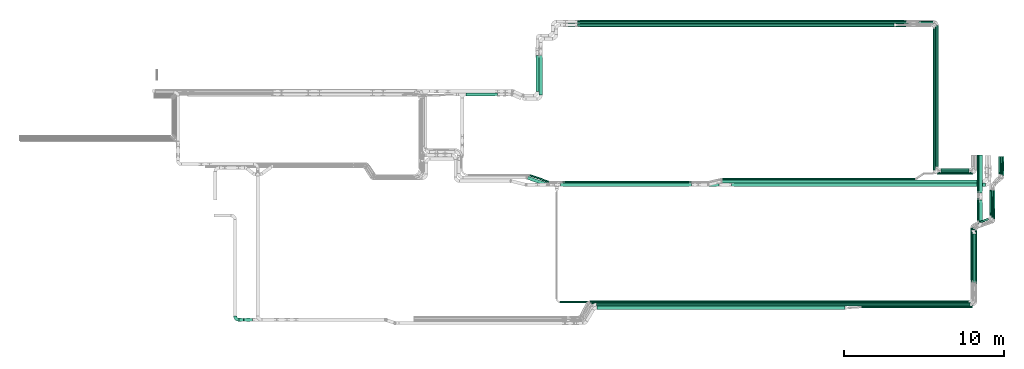
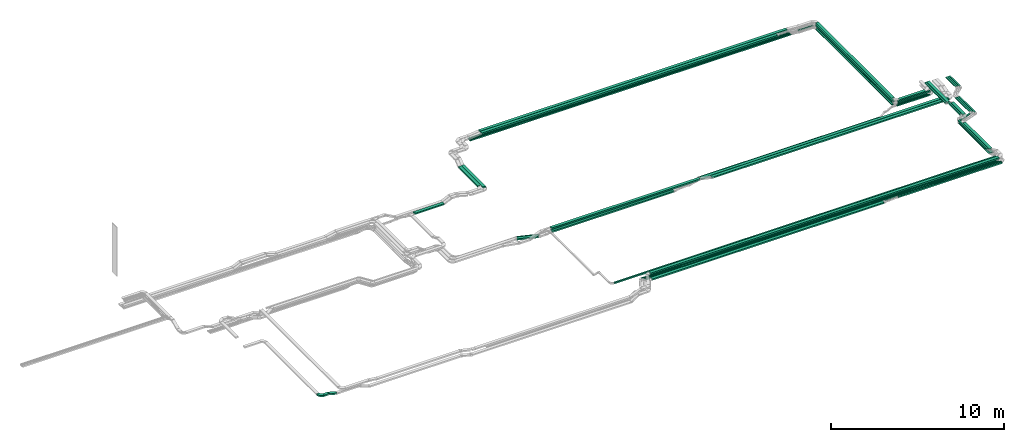
# One storey, part 2 of 23: 52 flow segments, 1 flow fitting.
"""IFC2X3 building model written with IfcOpenShell, lengths in millimetres."""

from ifc_helpers import new_model, entity, si_unit, converted_unit, derived_unit, direction, frame, frame_2d, origin, origin_2d_with_axis, place, context, subcontext, project, spatial, polyline, circle_curve, parameter, trimmed, segment, composite_curve, rectangle, outline, extrude, source, transform, mapped, material, type_object, type_shapes, element, save


model = new_model("IFC2X3")

# Units and contexts
model_context = context("Model", 3, precision=0.01, world=origin(), true_north=direction((6.12303176911189e-17, 1.0)))
body_context = subcontext(model_context, "Body", "Model", "MODEL_VIEW")
ifc_project = project(units=[si_unit("LENGTHUNIT", "METRE", prefix="MILLI"), si_unit("AREAUNIT", "SQUARE_METRE"), si_unit("VOLUMEUNIT", "CUBIC_METRE"), converted_unit("PLANEANGLEUNIT", "DEGREE", entity("IfcRatioMeasure", 0.0174532925199433), si_unit("PLANEANGLEUNIT", "RADIAN"), dimensions=[0, 0, 0, 0, 0, 0, 0]), si_unit("MASSUNIT", "GRAM", prefix="KILO"), derived_unit("MASSDENSITYUNIT", [(si_unit("MASSUNIT", "GRAM", prefix="KILO"), 1), (si_unit("LENGTHUNIT", "METRE"), -3)]), derived_unit("MOMENTOFINERTIAUNIT", [(si_unit("LENGTHUNIT", "METRE"), 4)]), si_unit("TIMEUNIT", "SECOND"), si_unit("FREQUENCYUNIT", "HERTZ"), si_unit("THERMODYNAMICTEMPERATUREUNIT", "DEGREE_CELSIUS"), derived_unit("THERMALTRANSMITTANCEUNIT", [(si_unit("MASSUNIT", "GRAM", prefix="KILO"), 1), (si_unit("THERMODYNAMICTEMPERATUREUNIT", "KELVIN"), -1), (si_unit("TIMEUNIT", "SECOND"), -3)]), derived_unit("VOLUMETRICFLOWRATEUNIT", [(si_unit("LENGTHUNIT", "METRE"), 3), (si_unit("TIMEUNIT", "SECOND"), -1)]), derived_unit("MASSFLOWRATEUNIT", [(si_unit("MASSUNIT", "GRAM", prefix="KILO"), 1), (si_unit("TIMEUNIT", "SECOND"), -1)]), derived_unit("ROTATIONALFREQUENCYUNIT", [(si_unit("TIMEUNIT", "SECOND"), -1)]), si_unit("ELECTRICCURRENTUNIT", "AMPERE"), si_unit("ELECTRICVOLTAGEUNIT", "VOLT"), si_unit("POWERUNIT", "WATT"), si_unit("FORCEUNIT", "NEWTON", prefix="KILO"), si_unit("ILLUMINANCEUNIT", "LUX"), si_unit("LUMINOUSFLUXUNIT", "LUMEN"), si_unit("LUMINOUSINTENSITYUNIT", "CANDELA"), derived_unit("USERDEFINED", [(si_unit("MASSUNIT", "GRAM", prefix="KILO"), -1), (si_unit("LENGTHUNIT", "METRE"), -2), (si_unit("TIMEUNIT", "SECOND"), 3), (si_unit("LUMINOUSFLUXUNIT", "LUMEN"), 1)]), derived_unit("LINEARVELOCITYUNIT", [(si_unit("LENGTHUNIT", "METRE"), 1), (si_unit("TIMEUNIT", "SECOND"), -1)]), si_unit("PRESSUREUNIT", "PASCAL"), derived_unit("USERDEFINED", [(si_unit("LENGTHUNIT", "METRE"), -2), (si_unit("MASSUNIT", "GRAM", prefix="KILO"), 1), (si_unit("TIMEUNIT", "SECOND"), -2)]), derived_unit("LINEARFORCEUNIT", [(si_unit("MASSUNIT", "GRAM", prefix="KILO"), 1), (si_unit("LENGTHUNIT", "METRE"), 1), (si_unit("TIMEUNIT", "SECOND"), -2), (si_unit("LENGTHUNIT", "METRE"), -1)]), derived_unit("PLANARFORCEUNIT", [(si_unit("MASSUNIT", "GRAM", prefix="KILO"), 1), (si_unit("LENGTHUNIT", "METRE"), 1), (si_unit("TIMEUNIT", "SECOND"), -2), (si_unit("LENGTHUNIT", "METRE"), -2)])], contexts=[model_context])

# Site, building, storey
site_placement = place(None, origin())
site = spatial("IfcSite", under=ifc_project, at=site_placement, CompositionType="ELEMENT")
building_placement = place(site_placement, origin())
building = spatial("IfcBuilding", under=site, at=building_placement, CompositionType="ELEMENT")
storey_placement = place(building_placement, frame((0.0, 0.0, 24000.0)))
storey = spatial("IfcBuildingStorey", under=building, at=storey_placement, CompositionType="ELEMENT", Elevation=24000.0)

# Flow segments
cable_carrier_segment_type = type_object("IfcCableCarrierSegmentType", PredefinedType="CABLETRAYSEGMENT")
flow_segment_1_placement = place(storey_placement, frame((35765.62, 14367.82, 2650.0)))
element("IfcFlowSegment", 1, at=flow_segment_1_placement, inside=storey, type_object=cable_carrier_segment_type, context=body_context, shape_type="SweptSolid", body=[
    extrude(rectangle(XDim=1961.74448976482, YDim=199.999999999998, at=origin_2d_with_axis()), frame((980.87, 100.0, 0.0)), (0.0, 0.0, 1.0), 100.000000000003),
])
for number, where in (
    (2, (65130.08, 9971.0, 2972.83)),
    (3, (65020.08, 9861.0, 2972.83)),
):
    element("IfcFlowSegment", number, at=place(storey_placement, frame(where)), inside=storey, type_object=cable_carrier_segment_type, context=body_context, shape_type="SweptSolid", body=[
        extrude(rectangle(XDim=8798.00000000002, YDim=99.9999999999946, at=origin_2d_with_axis()), frame((50.0, 4399.0, 0.0), z_axis=(0.0, 0.0, 1.0), x_axis=(0.0, -1.0, 0.0)), (0.0, 0.0, 1.0), 49.9999999999973),
    ])
flow_segment_2_placement = place(storey_placement, frame((21625.98, 315.0, 3300.0)))
element("IfcFlowSegment", 4, at=flow_segment_2_placement, inside=storey, type_object=cable_carrier_segment_type, context=body_context, shape_type="SweptSolid", body=[
    extrude(rectangle(XDim=280.71716103048, YDim=200.0, at=origin_2d_with_axis()), frame((140.36, 100.0, 0.0)), (0.0, 0.0, 1.0), 100.000000000003),
])
flow_segment_3_placement = place(storey_placement, frame((21909.72, 315.0, 3153.98)))
element("IfcFlowSegment", 5, at=flow_segment_3_placement, inside=storey, type_object=cable_carrier_segment_type, context=body_context, shape_type="SweptSolid", body=[
    extrude(rectangle(XDim=99.9999999999958, YDim=200.0, at=origin_2d_with_axis()), frame((13.25, 100.0, 193.83), z_axis=(0.964271449330498, 0.0, -0.26491616033391), x_axis=(0.26491616033391, 0.0, 0.964271449330498)), (0.0, 0.0, 1.0), 549.651195395299),
])
flow_segment_4_placement = place(storey_placement, frame((43924.88, 1069.69, 3217.23)))
element("IfcFlowSegment", 6, at=flow_segment_4_placement, inside=storey, type_object=cable_carrier_segment_type, context=body_context, shape_type="SweptSolid", body=[
    extrude(rectangle(XDim=15479.0908343116, YDim=200.0, at=origin_2d_with_axis()), frame((7739.55, 100.0, 0.0), z_axis=(0.0, 0.0, 1.0), x_axis=(-1.0, 0.0, 0.0)), (0.0, 0.0, 1.0), 100.000000000003),
])
flow_segment_5_placement = place(storey_placement, frame((51733.9, 9154.99, 2805.0)))
element("IfcFlowSegment", 7, at=flow_segment_5_placement, inside=storey, type_object=cable_carrier_segment_type, context=body_context, shape_type="SweptSolid", body=[
    extrude(rectangle(XDim=12038.4671980296, YDim=99.9999999999989, at=origin_2d_with_axis()), frame((6019.23, 50.0, 0.0)), (0.0, 0.0, 1.0), 49.9999999999973),
])
flow_segment_6_placement = place(storey_placement, frame((52335.62, 8734.99, 2805.0)))
element("IfcFlowSegment", 8, at=flow_segment_6_placement, inside=storey, type_object=cable_carrier_segment_type, context=body_context, shape_type="SweptSolid", body=[
    extrude(rectangle(XDim=15832.6193035877, YDim=200.0, at=origin_2d_with_axis()), frame((7916.31, 100.0, 0.0)), (0.0, 0.0, 1.0), 100.000000000003),
])
flow_segment_7_placement = place(storey_placement, frame((42732.4, 18910.0, 3245.4)))
element("IfcFlowSegment", 9, at=flow_segment_7_placement, inside=storey, type_object=cable_carrier_segment_type, context=body_context, shape_type="SweptSolid", body=[
    extrude(rectangle(XDim=20513.0370032506, YDim=200.000000000002, at=origin_2d_with_axis()), frame((10256.52, 100.0, 0.0)), (0.0, 0.0, 1.0), 100.000000000003),
])
flow_segment_8_placement = place(storey_placement, frame((42732.38, 18700.0, 3245.4)))
element("IfcFlowSegment", 10, at=flow_segment_8_placement, inside=storey, type_object=cable_carrier_segment_type, context=body_context, shape_type="SweptSolid", body=[
    extrude(rectangle(XDim=19736.1029536707, YDim=199.999999999998, at=origin_2d_with_axis()), frame((9868.05, 100.0, 0.0)), (0.0, 0.0, 1.0), 100.000000000003),
])
flow_segment_9_placement = place(storey_placement, frame((41967.53, 18700.0, 3045.4)))
element("IfcFlowSegment", 11, at=flow_segment_9_placement, inside=storey, type_object=cable_carrier_segment_type, context=body_context, shape_type="SweptSolid", body=[
    extrude(rectangle(XDim=21395.2924590022, YDim=99.9999999999989, at=origin_2d_with_axis()), frame((10697.65, 50.0, 0.0)), (0.0, 0.0, 1.0), 49.9999999999973),
])
flow_segment_10_placement = place(storey_placement, frame((41968.48, 18810.0, 3045.4)))
element("IfcFlowSegment", 12, at=flow_segment_10_placement, inside=storey, type_object=cable_carrier_segment_type, context=body_context, shape_type="SweptSolid", body=[
    extrude(rectangle(XDim=21395.2882878374, YDim=99.9999999999989, at=origin_2d_with_axis()), frame((10697.64, 50.0, 0.0)), (0.0, 0.0, 1.0), 49.9999999999973),
])
flow_segment_11_placement = place(storey_placement, frame((41967.53, 18920.0, 3045.4)))
element("IfcFlowSegment", 13, at=flow_segment_11_placement, inside=storey, type_object=cable_carrier_segment_type, context=body_context, shape_type="SweptSolid", body=[
    extrude(rectangle(XDim=21395.2924590022, YDim=99.9999999999989, at=origin_2d_with_axis()), frame((10697.65, 50.0, 0.0)), (0.0, 0.0, 1.0), 49.9999999999973),
])
flow_segment_12_placement = place(storey_placement, frame((41771.84, 8949.99, 2720.0)))
element("IfcFlowSegment", 14, at=flow_segment_12_placement, inside=storey, type_object=cable_carrier_segment_type, context=body_context, shape_type="SweptSolid", body=[
    extrude(rectangle(XDim=8053.84090120549, YDim=99.9999999999989, at=origin_2d_with_axis()), frame((4026.92, 50.0, 0.0), z_axis=(0.0, 0.0, 1.0), x_axis=(-1.0, 0.0, 0.0)), (0.0, 0.0, 1.0), 49.9999999999973),
])
flow_segment_13_placement = place(storey_placement, frame((41674.25, 8739.99, 2720.0)))
element("IfcFlowSegment", 15, at=flow_segment_13_placement, inside=storey, type_object=cable_carrier_segment_type, context=body_context, shape_type="SweptSolid", body=[
    extrude(rectangle(XDim=8148.49829971334, YDim=200.0, at=origin_2d_with_axis()), frame((4074.25, 100.0, 0.0), z_axis=(0.0, 0.0, 1.0), x_axis=(-1.0, 0.0, 0.0)), (0.0, 0.0, 1.0), 100.000000000003),
])
flow_segment_14_placement = place(storey_placement, frame((51739.88, 8944.99, 2805.0)))
element("IfcFlowSegment", 16, at=flow_segment_14_placement, inside=storey, type_object=cable_carrier_segment_type, context=body_context, shape_type="SweptSolid", body=[
    extrude(rectangle(XDim=16237.8207927538, YDim=200.0, at=origin_2d_with_axis()), frame((8118.91, 100.0, 0.0)), (0.0, 0.0, 1.0), 100.000000000003),
])
flow_segment_15_placement = place(storey_placement, frame((40330.6, 14420.31, 2883.62)))
element("IfcFlowSegment", 17, at=flow_segment_15_placement, inside=storey, type_object=cable_carrier_segment_type, context=body_context, shape_type="SweptSolid", body=[
    extrude(rectangle(XDim=2490.37832088763, YDim=200.000000000007, at=origin_2d_with_axis()), frame((100.0, 1245.19, 0.0), z_axis=(0.0, 0.0, 1.0), x_axis=(0.0, -1.0, 0.0)), (0.0, 0.0, 1.0), 100.000000000008),
])
flow_segment_16_placement = place(storey_placement, frame((40120.6, 14651.31, 2883.62)))
element("IfcFlowSegment", 18, at=flow_segment_16_placement, inside=storey, type_object=cable_carrier_segment_type, context=body_context, shape_type="SweptSolid", body=[
    extrude(rectangle(XDim=2256.12450469831, YDim=200.000000000007, at=origin_2d_with_axis()), frame((100.0, 1128.06, 0.0), z_axis=(0.0, 0.0, 1.0), x_axis=(0.0, -1.0, 0.0)), (0.0, 0.0, 1.0), 100.000000000003),
])
flow_segment_17_placement = place(storey_placement, frame((39578.79, 8759.66, 2660.0)))
element("IfcFlowSegment", 19, at=flow_segment_17_placement, inside=storey, type_object=cable_carrier_segment_type, context=body_context, shape_type="SweptSolid", body=[
    extrude(rectangle(XDim=1270.99252740195, YDim=200.000000000001, at=origin_2d_with_axis()), frame((633.16, 302.81, 0.0), z_axis=(0.0, 0.0, 1.0), x_axis=(-0.944737568154261, 0.327827587792688, 0.0)), (0.0, 0.0, 1.0), 100.000000000003),
])
flow_segment_18_placement = place(storey_placement, frame((39717.22, 8964.13, 2660.0)))
element("IfcFlowSegment", 20, at=flow_segment_18_placement, inside=storey, type_object=cable_carrier_segment_type, context=body_context, shape_type="SweptSolid", body=[
    extrude(rectangle(XDim=1287.8496907078, YDim=100.000000000007, at=origin_2d_with_axis()), frame((624.73, 258.33, 0.0), z_axis=(0.0, 0.0, 1.0), x_axis=(-0.944737568154257, 0.327827587792702, 0.0)), (0.0, 0.0, 1.0), 49.9999999999929),
])
flow_segment_19_placement = place(storey_placement, frame((41655.11, 8734.99, 2970.0)))
element("IfcFlowSegment", 21, at=flow_segment_19_placement, inside=storey, type_object=cable_carrier_segment_type, context=body_context, shape_type="SweptSolid", body=[
    extrude(rectangle(XDim=9887.21265595425, YDim=200.0, at=origin_2d_with_axis()), frame((4943.61, 100.0, 0.0), z_axis=(0.0, 0.0, 1.0), x_axis=(-1.0, 0.0, 0.0)), (0.0, 0.0, 1.0), 100.000000000003),
])
flow_segment_20_placement = place(storey_placement, frame((63984.79, 18920.0, 2972.83)))
element("IfcFlowSegment", 22, at=flow_segment_20_placement, inside=storey, type_object=cable_carrier_segment_type, context=body_context, shape_type="SweptSolid", body=[
    extrude(rectangle(XDim=994.292459002089, YDim=99.9999999999989, at=origin_2d_with_axis()), frame((497.15, 50.0, 0.0), z_axis=(0.0, 0.0, 1.0), x_axis=(-1.0, 0.0, 0.0)), (0.0, 0.0, 1.0), 49.9999999999973),
])
flow_segment_21_placement = place(storey_placement, frame((65381.08, 9720.0, 2972.83)))
element("IfcFlowSegment", 23, at=flow_segment_21_placement, inside=storey, type_object=cable_carrier_segment_type, context=body_context, shape_type="SweptSolid", body=[
    extrude(rectangle(XDim=1753.44655483797, YDim=99.9999999999989, at=origin_2d_with_axis()), frame((876.72, 50.0, 0.0)), (0.0, 0.0, 1.0), 49.9999999999973),
])
flow_segment_22_placement = place(storey_placement, frame((65271.08, 9610.0, 2972.83)))
element("IfcFlowSegment", 24, at=flow_segment_22_placement, inside=storey, type_object=cable_carrier_segment_type, context=body_context, shape_type="SweptSolid", body=[
    extrude(rectangle(XDim=1973.44655483796, YDim=99.9999999999989, at=origin_2d_with_axis()), frame((986.72, 50.0, 0.0)), (0.0, 0.0, 1.0), 49.9999999999973),
])
flow_segment_23_placement = place(storey_placement, frame((64910.08, 9730.0, 2972.83)))
element("IfcFlowSegment", 25, at=flow_segment_23_placement, inside=storey, type_object=cable_carrier_segment_type, context=body_context, shape_type="SweptSolid", body=[
    extrude(rectangle(XDim=8819.00000000003, YDim=99.9999999999946, at=origin_2d_with_axis()), frame((50.0, 4409.5, 0.0), z_axis=(0.0, 0.0, 1.0), x_axis=(0.0, -1.0, 0.0)), (0.0, 0.0, 1.0), 49.9999999999973),
])
flow_segment_24_placement = place(storey_placement, frame((65030.08, 9961.0, 3187.83)))
element("IfcFlowSegment", 26, at=flow_segment_24_placement, inside=storey, type_object=cable_carrier_segment_type, context=body_context, shape_type="SweptSolid", body=[
    extrude(rectangle(XDim=8798.00000000003, YDim=200.000000000007, at=origin_2d_with_axis()), frame((100.0, 4399.0, 0.0), z_axis=(0.0, 0.0, 1.0), x_axis=(0.0, -1.0, 0.0)), (0.0, 0.0, 1.0), 100.000000000003),
])
flow_segment_25_placement = place(storey_placement, frame((65381.08, 9610.0, 3187.83)))
element("IfcFlowSegment", 27, at=flow_segment_25_placement, inside=storey, type_object=cable_carrier_segment_type, context=body_context, shape_type="SweptSolid", body=[
    extrude(rectangle(XDim=1738.00000000001, YDim=200.0, at=origin_2d_with_axis()), frame((869.0, 100.0, 0.0), z_axis=(0.0, 0.0, 1.0), x_axis=(-1.0, 0.0, 0.0)), (0.0, 0.0, 1.0), 100.000000000003),
])
flow_segment_26_placement = place(storey_placement, frame((65140.08, 9500.0, 2972.83)))
element("IfcFlowSegment", 28, at=flow_segment_26_placement, inside=storey, type_object=cable_carrier_segment_type, context=body_context, shape_type="SweptSolid", body=[
    extrude(rectangle(XDim=2214.44655483797, YDim=99.9999999999989, at=origin_2d_with_axis()), frame((1107.22, 50.0, 0.0), z_axis=(0.0, 0.0, 1.0), x_axis=(-1.0, 0.0, 0.0)), (0.0, 0.0, 1.0), 49.9999999999973),
])
flow_segment_27_placement = place(storey_placement, frame((64920.08, 9751.0, 3187.83)))
element("IfcFlowSegment", 29, at=flow_segment_27_placement, inside=storey, type_object=cable_carrier_segment_type, context=body_context, shape_type="SweptSolid", body=[
    extrude(rectangle(XDim=8848.00000000016, YDim=99.9999999999946, at=origin_2d_with_axis()), frame((50.0, 4424.0, 0.0), z_axis=(0.0, 0.0, 1.0), x_axis=(0.0, -1.0, 0.0)), (0.0, 0.0, 1.0), 100.000000000003),
])
flow_segment_28_placement = place(storey_placement, frame((65171.08, 9500.0, 3187.83)))
element("IfcFlowSegment", 30, at=flow_segment_28_placement, inside=storey, type_object=cable_carrier_segment_type, context=body_context, shape_type="SweptSolid", body=[
    extrude(rectangle(XDim=2183.44655483798, YDim=99.9999999999989, at=origin_2d_with_axis()), frame((1091.72, 50.0, 0.0)), (0.0, 0.0, 1.0), 100.000000000003),
])
flow_segment_29_placement = place(storey_placement, frame((67766.35, 8313.75, 2955.27)))
element("IfcFlowSegment", 31, at=flow_segment_29_placement, inside=storey, type_object=cable_carrier_segment_type, context=body_context, shape_type="SweptSolid", body=[
    extrude(rectangle(XDim=2386.77265957814, YDim=200.000000000007, at=origin_2d_with_axis()), frame((100.0, 1193.39, 0.0), z_axis=(0.0, 0.0, 1.0), x_axis=(0.0, 1.0, 0.0)), (0.0, 0.0, 1.0), 100.000000000003),
])
flow_segment_30_placement = place(storey_placement, frame((68996.32, 9477.22, 2970.08)))
element("IfcFlowSegment", 32, at=flow_segment_30_placement, inside=storey, type_object=cable_carrier_segment_type, context=body_context, shape_type="SweptSolid", body=[
    extrude(rectangle(XDim=49.9999999999984, YDim=1113.08678124436, at=frame_2d((0.0, 0.0), x_axis=(0.0, 1.0))), frame((0.0, 556.66, 27.83), z_axis=(1.0, -1.28642484897292e-06, 6.54438427708494e-09), x_axis=(1.28644149537419e-06, 0.999987060117084, -0.00508719930179811)), (0.0, 0.0, 1.0), 100.000000000017),
])
flow_segment_31_placement = place(storey_placement, frame((69106.32, 9459.66, 2970.08)))
element("IfcFlowSegment", 33, at=flow_segment_31_placement, inside=storey, type_object=cable_carrier_segment_type, context=body_context, shape_type="SweptSolid", body=[
    extrude(rectangle(XDim=50.0000000000039, YDim=1130.64982762595, at=frame_2d((0.0, 0.0), x_axis=(0.0, 1.0))), frame((0.0, 565.44, 27.8), z_axis=(1.0, -1.19737642217187e-06, 5.92293818108424e-09), x_axis=(1.1973910712753e-06, 0.999987765814664, -0.00494653611768659)), (0.0, 0.0, 1.0), 99.9999999999969),
])
flow_segment_32_placement = place(storey_placement, frame((69216.32, 9406.28, 2970.08)))
element("IfcFlowSegment", 34, at=flow_segment_32_placement, inside=storey, type_object=cable_carrier_segment_type, context=body_context, shape_type="SweptSolid", body=[
    extrude(rectangle(XDim=50.0000000000024, YDim=1184.03397215071, at=frame_2d((0.0, 0.0), x_axis=(0.0, 1.0))), frame((0.0, 592.13, 27.86), z_axis=(1.0, 0.0, 0.0), x_axis=(0.0, 0.999988349268031, -0.00482714493236797)), (0.0, 0.0, 1.0), 100.000000000003),
])
flow_segment_33_placement = place(storey_placement, frame((67460.79, 6325.18, 2990.05)))
element("IfcFlowSegment", 35, at=flow_segment_33_placement, inside=storey, type_object=cable_carrier_segment_type, context=body_context, shape_type="SweptSolid", body=[
    extrude(rectangle(XDim=936.699448046719, YDim=99.999999950971, at=origin_2d_with_axis()), frame((455.13, 214.62, 0.01), z_axis=(2.92307110406685e-05, 1.12284692556801e-05, 1.0), x_axis=(-0.933496521062262, -0.358586452873139, 3.13131440415812e-05)), (0.0, 0.0, 1.0), 49.9999999754865),
])
flow_segment_34_placement = place(storey_placement, frame((67656.35, 8312.3, 2955.27)))
element("IfcFlowSegment", 36, at=flow_segment_34_placement, inside=storey, type_object=cable_carrier_segment_type, context=body_context, shape_type="SweptSolid", body=[
    extrude(rectangle(XDim=2376.94076012938, YDim=99.9999999999946, at=origin_2d_with_axis()), frame((50.0, 1188.47, 0.0), z_axis=(0.0, 0.0, 1.0), x_axis=(0.0, 1.0, 0.0)), (0.0, 0.0, 1.0), 100.000000000008),
])
flow_segment_35_placement = place(storey_placement, frame((67766.35, 6490.72, 3190.89)))
element("IfcFlowSegment", 37, at=flow_segment_35_placement, inside=storey, type_object=cable_carrier_segment_type, context=body_context, shape_type="SweptSolid", body=[
    extrude(rectangle(XDim=1383.98185180537, YDim=200.000000000007, at=origin_2d_with_axis()), frame((100.0, 691.99, 0.0), z_axis=(0.0, 0.0, 1.0), x_axis=(0.0, -1.0, 0.0)), (0.0, 0.0, 1.0), 100.000000000003),
])
flow_segment_36_placement = place(storey_placement, frame((67656.35, 6589.61, 3190.89)))
element("IfcFlowSegment", 38, at=flow_segment_36_placement, inside=storey, type_object=cable_carrier_segment_type, context=body_context, shape_type="SweptSolid", body=[
    extrude(rectangle(XDim=1440.33081274158, YDim=99.9999999999946, at=origin_2d_with_axis()), frame((50.0, 720.17, 0.0), z_axis=(0.0, 0.0, 1.0), x_axis=(0.0, -1.0, 0.0)), (0.0, 0.0, 1.0), 99.9999999999989),
])
flow_segment_37_placement = place(storey_placement, frame((67299.5, 2648.59, 2990.08)))
element("IfcFlowSegment", 39, at=flow_segment_37_placement, inside=storey, type_object=cable_carrier_segment_type, context=body_context, shape_type="SweptSolid", body=[
    extrude(rectangle(XDim=3535.21004703669, YDim=99.9999999999946, at=origin_2d_with_axis()), frame((50.0, 1767.61, 0.0), z_axis=(0.0, 0.0, 1.0), x_axis=(0.0, -1.0, 0.0)), (0.0, 0.0, 1.0), 49.9999999999973),
])
flow_segment_38_placement = place(storey_placement, frame((67409.5, 2647.82, 2990.08)))
element("IfcFlowSegment", 40, at=flow_segment_38_placement, inside=storey, type_object=cable_carrier_segment_type, context=body_context, shape_type="SweptSolid", body=[
    extrude(rectangle(XDim=3441.21407318068, YDim=99.9999999999946, at=origin_2d_with_axis()), frame((50.0, 1720.61, 0.0), z_axis=(0.0, 0.0, 1.0), x_axis=(0.0, -1.0, 0.0)), (0.0, 0.0, 1.0), 49.9999999999973),
])
flow_segment_39_placement = place(storey_placement, frame((67519.5, 2648.59, 2990.08)))
element("IfcFlowSegment", 41, at=flow_segment_39_placement, inside=storey, type_object=cable_carrier_segment_type, context=body_context, shape_type="SweptSolid", body=[
    extrude(rectangle(XDim=3340.44295348635, YDim=99.9999999999946, at=origin_2d_with_axis()), frame((50.0, 1670.22, 0.0), z_axis=(0.0, 0.0, 1.0), x_axis=(0.0, -1.0, 0.0)), (0.0, 0.0, 1.0), 49.9999999999973),
])
flow_segment_40_placement = place(storey_placement, frame((67245.11, 2757.32, 3190.89)))
element("IfcFlowSegment", 42, at=flow_segment_40_placement, inside=storey, type_object=cable_carrier_segment_type, context=body_context, shape_type="SweptSolid", body=[
    extrude(rectangle(XDim=3397.478378517, YDim=99.9999999999946, at=origin_2d_with_axis()), frame((50.0, 1698.74, 0.0), z_axis=(0.0, 0.0, 1.0), x_axis=(0.0, -1.0, 0.0)), (0.0, 0.0, 1.0), 100.000000000003),
])
flow_segment_41_placement = place(storey_placement, frame((67355.11, 2736.46, 3190.89)))
element("IfcFlowSegment", 43, at=flow_segment_41_placement, inside=storey, type_object=cable_carrier_segment_type, context=body_context, shape_type="SweptSolid", body=[
    extrude(rectangle(XDim=3038.23193146577, YDim=200.000000000007, at=origin_2d_with_axis()), frame((100.0, 1519.12, 0.0), z_axis=(0.0, 0.0, 1.0), x_axis=(0.0, -1.0, 0.0)), (0.0, 0.0, 1.0), 100.000000000003),
])
flow_segment_42_placement = place(storey_placement, frame((68429.09, 6890.94, 2981.06)))
element("IfcFlowSegment", 44, at=flow_segment_42_placement, inside=storey, type_object=cable_carrier_segment_type, context=body_context, shape_type="SweptSolid", body=[
    extrude(rectangle(XDim=50.0000000000052, YDim=1632.87479562661, at=frame_2d((0.0, 0.0), x_axis=(0.0, 1.0))), frame((0.0, 816.55, 29.15), z_axis=(1.0, 4.2303503585612e-07, -2.15209675786711e-09), x_axis=(-4.23040509977761e-07, 0.999987060053235, -0.00508721199766992)), (0.0, 0.0, 1.0), 100.000000000004),
])
flow_segment_43_placement = place(storey_placement, frame((68539.09, 6775.01, 2980.84)))
element("IfcFlowSegment", 45, at=flow_segment_43_placement, inside=storey, type_object=cable_carrier_segment_type, context=body_context, shape_type="SweptSolid", body=[
    extrude(rectangle(XDim=50.0000000000028, YDim=1731.24609064818, at=frame_2d((0.0, 0.0), x_axis=(0.0, 1.0))), frame((0.0, 865.74, 29.28), z_axis=(1.0, 3.59023911304355e-07, -1.77595038103171e-09), x_axis=(-3.59028303742244e-07, 0.999987765761455, -0.00494654700623993)), (0.0, 0.0, 1.0), 99.9999999999923),
])
flow_segment_44_placement = place(storey_placement, frame((68649.09, 6675.01, 2980.6)))
element("IfcFlowSegment", 46, at=flow_segment_44_placement, inside=storey, type_object=cable_carrier_segment_type, context=body_context, shape_type="SweptSolid", body=[
    extrude(rectangle(XDim=50.0000000000024, YDim=1826.30314614533, at=frame_2d((0.0, 0.0), x_axis=(0.0, 1.0))), frame((0.0, 913.26, 29.41), z_axis=(1.0, 0.0, 0.0), x_axis=(0.0, 0.999988349268031, -0.004827144932381)), (0.0, 0.0, 1.0), 99.9999999999946),
])
flow_segment_45_placement = place(storey_placement, frame((43501.04, 1499.69, 3217.23)))
element("IfcFlowSegment", 47, at=flow_segment_45_placement, inside=storey, type_object=cable_carrier_segment_type, context=body_context, shape_type="SweptSolid", body=[
    extrude(rectangle(XDim=23647.4665084234, YDim=100.0, at=origin_2d_with_axis()), frame((11823.73, 50.0, 0.0)), (0.0, 0.0, 1.0), 49.9999999999973),
])
flow_segment_46_placement = place(storey_placement, frame((43588.44, 1389.69, 3217.23)))
element("IfcFlowSegment", 48, at=flow_segment_46_placement, inside=storey, type_object=cable_carrier_segment_type, context=body_context, shape_type="SweptSolid", body=[
    extrude(rectangle(XDim=23670.0611041195, YDim=100.0, at=origin_2d_with_axis()), frame((11835.03, 50.0, 0.0)), (0.0, 0.0, 1.0), 49.9999999999973),
])
flow_segment_47_placement = place(storey_placement, frame((43681.42, 1279.69, 3217.23)))
element("IfcFlowSegment", 49, at=flow_segment_47_placement, inside=storey, type_object=cable_carrier_segment_type, context=body_context, shape_type="SweptSolid", body=[
    extrude(rectangle(XDim=23687.084063233, YDim=100.0, at=origin_2d_with_axis()), frame((11843.54, 50.0, 0.0)), (0.0, 0.0, 1.0), 49.9999999999973),
])
flow_segment_48_placement = place(storey_placement, frame((41626.11, 1479.69, 3517.23)))
element("IfcFlowSegment", 50, at=flow_segment_48_placement, inside=storey, type_object=cable_carrier_segment_type, context=body_context, shape_type="SweptSolid", body=[
    extrude(rectangle(XDim=25468.0034125721, YDim=100.0, at=origin_2d_with_axis()), frame((12734.0, 50.0, 0.0)), (0.0, 0.0, 1.0), 100.000000000003),
])
flow_segment_49_placement = place(storey_placement, frame((43911.56, 1269.69, 3517.23)))
element("IfcFlowSegment", 51, at=flow_segment_49_placement, inside=storey, type_object=cable_carrier_segment_type, context=body_context, shape_type="SweptSolid", body=[
    extrude(rectangle(XDim=23292.5485258712, YDim=200.0, at=origin_2d_with_axis()), frame((11646.27, 100.0, 0.0)), (0.0, 0.0, 1.0), 100.000000000003),
])
flow_segment_50_placement = place(storey_placement, frame((60401.42, 1159.69, 3217.23)))
element("IfcFlowSegment", 52, at=flow_segment_50_placement, inside=storey, type_object=cable_carrier_segment_type, context=body_context, shape_type="SweptSolid", body=[
    extrude(rectangle(XDim=6932.5550865982, YDim=100.0, at=origin_2d_with_axis()), frame((3466.28, 50.0, 0.0)), (0.0, 0.0, 1.0), 100.000000000003),
])

# Flow fitting
ifc_material = material()
cable_carrier_fitting_type = type_object("IfcCableCarrierFittingType", Name="470_DKC_S5_Variable Angle Elbow 0-45:-", PredefinedType="NOTDEFINED", material=ifc_material)
shared_shape = source(origin(), body_context, "Body", "SweptSolid", [
    extrude(outline(composite_curve([segment(polyline([(-125.75, -225.25), (-124.75, -225.25)]), True, "CONTINUOUS"), segment(trimmed(circle_curve(frame_2d((-124.75, 124.75), x_axis=(0.0, -1.0)), 350.0), [parameter(0.0)], [parameter(90.0000000000001)], True, "PARAMETER"), True, "CONTINUOUS"), segment(polyline([(225.25, 124.75), (225.25, 125.75)]), True, "CONTINUOUS"), segment(polyline([(225.25, 125.75), (25.25, 125.75)]), True, "CONTINUOUS"), segment(polyline([(25.25, 125.75), (25.25, 124.75)]), True, "CONTINUOUS"), segment(trimmed(circle_curve(frame_2d((-124.75, 124.75), x_axis=(0.0, -1.0)), 150.0), [parameter(0.0)], [parameter(90.0000000000001)], True, "PARAMETER"), False, "CONTINUOUS"), segment(polyline([(-124.75, -25.25), (-125.75, -25.25)]), True, "CONTINUOUS"), segment(polyline([(-125.75, -25.25), (-125.75, -225.25)]), True, "CONTINUOUS")], self_intersect=False)), frame((-125.25, 125.25, -50.0)), (0.0, 0.0, 1.0), 100.0),
])
type_shapes(cable_carrier_fitting_type, [shared_shape])
flow_fitting_placement = place(storey_placement, frame((21374.98, 415.0, 3350.0), z_axis=(0.0, 0.0, 1.0), x_axis=(0.0, -1.0, 0.0)))
element("IfcFlowFitting", 53, at=flow_fitting_placement, inside=storey, type_object=cable_carrier_fitting_type, material=ifc_material, Name="470_DKC_S5_Variable Angle Elbow 0-45:-", ObjectType="470_DKC_S5_Variable Angle Elbow 0-45:-", context=body_context, shape_type="MappedRepresentation", body=[
    mapped(shared_shape, transform((0.0, 0.0, 0.0), scale=1.0)),
])

save(model, "model.ifc")
